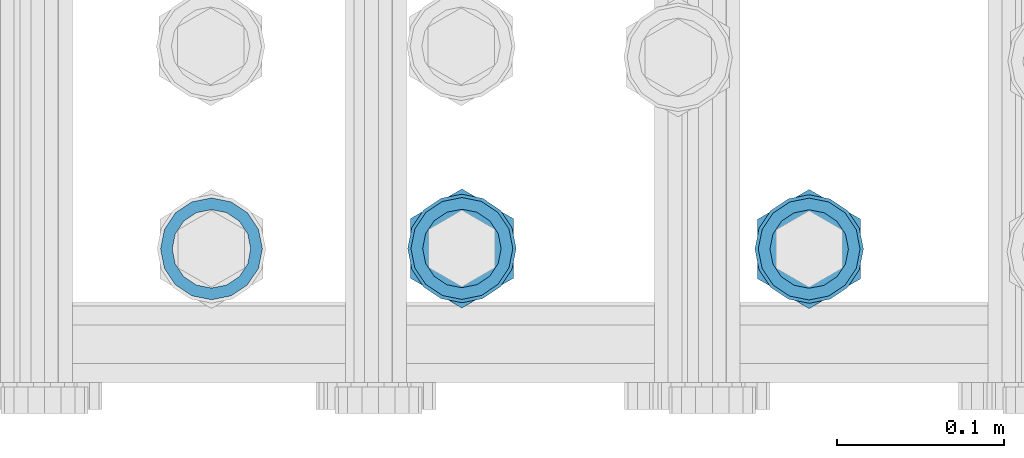
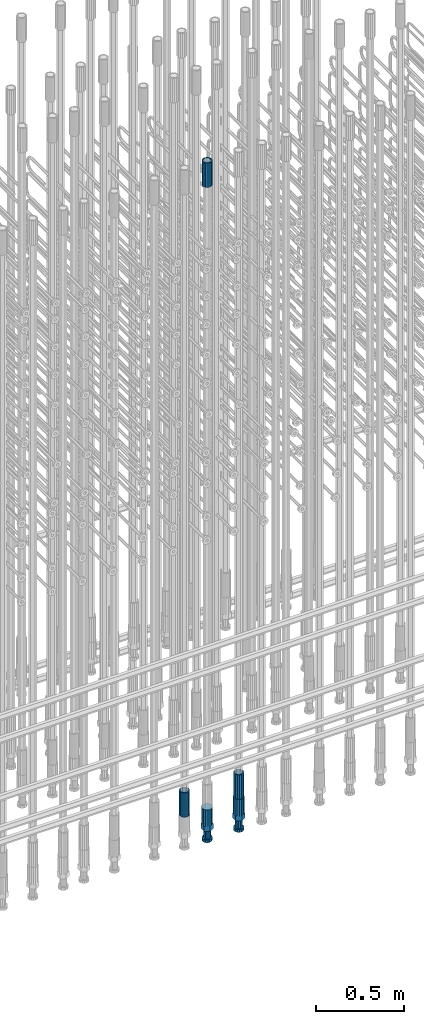
# One storey, part 65 of 177: 5 beams.
"""IFC2X3 building model written with IfcOpenShell, lengths in millimetres."""

from ifc_helpers import new_model, si_unit, frame, origin_with_axes, place, context, subcontext, project, spatial, faceted_brep, material, type_object, element, save


model = new_model("IFC2X3")

# Units and contexts
model_context_1 = context("Model", 3, precision=1e-05, world=origin_with_axes())
model_context_2 = context("Model", 3, precision=1e-05, world=origin_with_axes())
body_context = subcontext(model_context_2, "Body", "Model", "MODEL_VIEW")
ifc_project = project(units=[si_unit("LENGTHUNIT", "METRE", prefix="MILLI"), si_unit("AREAUNIT", "SQUARE_METRE"), si_unit("VOLUMEUNIT", "CUBIC_METRE"), si_unit("MASSUNIT", "GRAM", prefix="KILO"), si_unit("TIMEUNIT", "SECOND"), si_unit("PLANEANGLEUNIT", "RADIAN"), si_unit("SOLIDANGLEUNIT", "STERADIAN"), si_unit("THERMODYNAMICTEMPERATUREUNIT", "DEGREE_CELSIUS"), si_unit("LUMINOUSINTENSITYUNIT", "LUMEN")], contexts=[model_context_1])

# Site, building, storey
site_placement = place(None, origin_with_axes())
site = spatial("IfcSite", under=ifc_project, at=site_placement, CompositionType="ELEMENT")
building_placement = place(site_placement, origin_with_axes())
building = spatial("IfcBuilding", under=site, at=building_placement, Name="Undefined", CompositionType="ELEMENT")
storey_placement = place(building_placement, origin_with_axes())
storey = spatial("IfcBuildingStorey", under=building, at=storey_placement, Name="Undefined", CompositionType="ELEMENT", Elevation=0.0)

# Beams
ifc_material = material(Name="STEEL/S275")
beam_type_1 = type_object("IfcBeamType", PredefinedType="NOTDEFINED")
beam_1_placement = place(storey_placement, frame((2033585.99818842, 6205156.39605988, 22659.9858194829), z_axis=(1.0, 0.0, 0.0), x_axis=(0.0, 0.0, 1.0)))
element("IfcBeam", 1, at=beam_1_placement, inside=storey, type_object=beam_type_1, material=ifc_material, Name="AG40N", context=body_context, shape_type="Brep", body=[
    faceted_brep([(0.0, -23.5000000001164, -9.31322574615479e-10), (0.0, -21.7111690140155, 8.99306066054851), (170.0, -21.7111690140155, 8.99306066054851), (170.0, -23.5, 0.0), (0.0, -16.6170093578839, 16.6170093575493), (170.0, -16.6170093578839, 16.6170093575493), (0.0, -8.99306066057943, 21.7111690137535), (170.0, -8.99306066057943, 21.7111690137535), (0.0, 1.16415321826935e-10, 23.5), (170.0, 0.0, 23.5), (0.0, 8.99306066057943, 21.7111690137535), (170.0, 8.99306066057943, 21.7111690137535), (0.0, 16.6170093578839, 16.6170093575493), (170.0, 16.6170093578839, 16.6170093575493), (0.0, 21.7111690140155, 8.99306066054851), (170.0, 21.7111690140155, 8.99306066054851), (0.0, 23.5000000001164, -9.31322574615479e-10), (170.0, 23.5, 0.0), (0.0, 21.7111690140155, -8.99306066054851), (170.0, 21.7111690140155, -8.99306066054851), (0.0, 16.6170093578839, -16.6170093575493), (170.0, 16.6170093578839, -16.6170093575493), (0.0, 8.99306066057943, -21.7111690137535), (170.0, 8.99306066057943, -21.7111690137535), (0.0, 1.16415321826935e-10, -23.5000000009313), (170.0, 0.0, -23.5), (0.0, -8.99306066057943, -21.7111690137535), (170.0, -8.99306066057943, -21.7111690137535), (0.0, -16.6170093578839, -16.6170093575493), (170.0, -16.6170093578839, -16.6170093575493), (0.0, -21.7111690140155, -8.99306066054851), (170.0, -21.7111690140155, -8.99306066054851), (0.0, -30.5, 0.0), (0.0, -28.1783257415937, -11.6718446873128), (170.0, -28.1783257415937, -11.6718446873128), (170.0, -30.5, 0.0), (0.0, -21.5667568261888, -21.5667568258941), (170.0, -21.5667568261888, -21.5667568258941), (0.0, -11.6718446871346, -28.1783257415518), (170.0, -11.6718446871346, -28.1783257415518), (0.0, 0.0, -30.5), (170.0, 0.0, -30.5), (0.0, 11.6718446871346, -28.1783257415518), (170.0, 11.6718446871346, -28.1783257415518), (0.0, 21.5667568261888, -21.5667568258941), (170.0, 21.5667568261888, -21.5667568258941), (0.0, 28.1783257415937, -11.6718446873128), (170.0, 28.1783257415937, -11.6718446873128), (0.0, 30.5, 0.0), (170.0, 30.5, 0.0), (0.0, 28.1783257415937, 11.6718446873128), (170.0, 28.1783257415937, 11.6718446873128), (0.0, 21.5667568261888, 21.5667568258941), (170.0, 21.5667568261888, 21.5667568258941), (0.0, 11.6718446871346, 28.1783257415518), (170.0, 11.6718446871346, 28.1783257415518), (0.0, 0.0, 30.5), (170.0, 0.0, 30.5), (0.0, -11.6718446871346, 28.1783257415518), (170.0, -11.6718446871346, 28.1783257415518), (0.0, -21.5667568261888, 21.5667568258941), (170.0, -21.5667568261888, 21.5667568258941), (0.0, -28.1783257415937, 11.6718446873128), (170.0, -28.1783257415937, 11.6718446873128)], [[[0, 1, 2, 3]], [[1, 4, 5, 2]], [[4, 6, 7, 5]], [[6, 8, 9, 7]], [[8, 10, 11, 9]], [[10, 12, 13, 11]], [[12, 14, 15, 13]], [[14, 16, 17, 15]], [[16, 18, 19, 17]], [[18, 20, 21, 19]], [[20, 22, 23, 21]], [[22, 24, 25, 23]], [[24, 26, 27, 25]], [[26, 28, 29, 27]], [[28, 30, 31, 29]], [[30, 0, 3, 31]], [[32, 33, 34, 35]], [[33, 36, 37, 34]], [[36, 38, 39, 37]], [[38, 40, 41, 39]], [[40, 42, 43, 41]], [[42, 44, 45, 43]], [[44, 46, 47, 45]], [[46, 48, 49, 47]], [[48, 50, 51, 49]], [[50, 52, 53, 51]], [[52, 54, 55, 53]], [[54, 56, 57, 55]], [[56, 58, 59, 57]], [[58, 60, 61, 59]], [[60, 62, 63, 61]], [[62, 32, 35, 63]], [[37, 39, 41, 43, 45, 47, 49, 51, 53, 55, 57, 59, 61, 63, 35, 34], [5, 7, 9, 11, 13, 15, 17, 19, 21, 23, 25, 27, 29, 31, 3, 2]], [[62, 60, 58, 56, 54, 52, 50, 48, 46, 44, 42, 40, 38, 36, 33, 32], [30, 28, 26, 24, 22, 20, 18, 16, 14, 12, 10, 8, 6, 4, 1, 0]]]),
])
beam_2_placement = place(storey_placement, frame((2033794.01713976, 6205156.06372311, 18490.9668004301), z_axis=(-1.0, 0.0, 0.0), x_axis=(0.0, 0.0, -1.0)))
element("IfcBeam", 2, at=beam_2_placement, inside=storey, type_object=beam_type_1, material=ifc_material, Name="AG40N", context=body_context, shape_type="Brep", body=[
    faceted_brep([(0.0, -23.5000000001164, -9.31322574615479e-10), (0.0, -21.7111690140155, 8.99306066054851), (170.0, -21.7111690140155, 8.99306066054851), (170.0, -23.5, 0.0), (0.0, -16.6170093578839, 16.6170093575493), (170.0, -16.6170093578839, 16.6170093575493), (0.0, -8.99306066057943, 21.7111690137535), (170.0, -8.99306066057943, 21.7111690137535), (0.0, 1.16415321826935e-10, 23.5), (170.0, 0.0, 23.5), (0.0, 8.99306066057943, 21.7111690137535), (170.0, 8.99306066057943, 21.7111690137535), (0.0, 16.6170093578839, 16.6170093575493), (170.0, 16.6170093578839, 16.6170093575493), (0.0, 21.7111690140155, 8.99306066054851), (170.0, 21.7111690140155, 8.99306066054851), (0.0, 23.5000000001164, -9.31322574615479e-10), (170.0, 23.5, 0.0), (0.0, 21.7111690140155, -8.99306066054851), (170.0, 21.7111690140155, -8.99306066054851), (0.0, 16.6170093578839, -16.6170093575493), (170.0, 16.6170093578839, -16.6170093575493), (0.0, 8.99306066057943, -21.7111690137535), (170.0, 8.99306066057943, -21.7111690137535), (0.0, 1.16415321826935e-10, -23.5000000009313), (170.0, 0.0, -23.5), (0.0, -8.99306066057943, -21.7111690137535), (170.0, -8.99306066057943, -21.7111690137535), (0.0, -16.6170093578839, -16.6170093575493), (170.0, -16.6170093578839, -16.6170093575493), (0.0, -21.7111690140155, -8.99306066054851), (170.0, -21.7111690140155, -8.99306066054851), (0.0, -30.5, 0.0), (0.0, -28.1783257415937, -11.6718446873128), (170.0, -28.1783257415937, -11.6718446873128), (170.0, -30.5, 0.0), (0.0, -21.5667568261888, -21.5667568258941), (170.0, -21.5667568261888, -21.5667568258941), (0.0, -11.6718446871346, -28.1783257415518), (170.0, -11.6718446871346, -28.1783257415518), (0.0, 0.0, -30.5), (170.0, 0.0, -30.5), (0.0, 11.6718446871346, -28.1783257415518), (170.0, 11.6718446871346, -28.1783257415518), (0.0, 21.5667568261888, -21.5667568258941), (170.0, 21.5667568261888, -21.5667568258941), (0.0, 28.1783257415937, -11.6718446873128), (170.0, 28.1783257415937, -11.6718446873128), (0.0, 30.5, 0.0), (170.0, 30.5, 0.0), (0.0, 28.1783257415937, 11.6718446873128), (170.0, 28.1783257415937, 11.6718446873128), (0.0, 21.5667568261888, 21.5667568258941), (170.0, 21.5667568261888, 21.5667568258941), (0.0, 11.6718446871346, 28.1783257415518), (170.0, 11.6718446871346, 28.1783257415518), (0.0, 0.0, 30.5), (170.0, 0.0, 30.5), (0.0, -11.6718446871346, 28.1783257415518), (170.0, -11.6718446871346, 28.1783257415518), (0.0, -21.5667568261888, 21.5667568258941), (170.0, -21.5667568261888, 21.5667568258941), (0.0, -28.1783257415937, 11.6718446873128), (170.0, -28.1783257415937, 11.6718446873128)], [[[0, 1, 2, 3]], [[1, 4, 5, 2]], [[4, 6, 7, 5]], [[6, 8, 9, 7]], [[8, 10, 11, 9]], [[10, 12, 13, 11]], [[12, 14, 15, 13]], [[14, 16, 17, 15]], [[16, 18, 19, 17]], [[18, 20, 21, 19]], [[20, 22, 23, 21]], [[22, 24, 25, 23]], [[24, 26, 27, 25]], [[26, 28, 29, 27]], [[28, 30, 31, 29]], [[30, 0, 3, 31]], [[32, 33, 34, 35]], [[33, 36, 37, 34]], [[36, 38, 39, 37]], [[38, 40, 41, 39]], [[40, 42, 43, 41]], [[42, 44, 45, 43]], [[44, 46, 47, 45]], [[46, 48, 49, 47]], [[48, 50, 51, 49]], [[50, 52, 53, 51]], [[52, 54, 55, 53]], [[54, 56, 57, 55]], [[56, 58, 59, 57]], [[58, 60, 61, 59]], [[60, 62, 63, 61]], [[62, 32, 35, 63]], [[37, 39, 41, 43, 45, 47, 49, 51, 53, 55, 57, 59, 61, 63, 35, 34], [5, 7, 9, 11, 13, 15, 17, 19, 21, 23, 25, 27, 29, 31, 3, 2]], [[62, 60, 58, 56, 54, 52, 50, 48, 46, 44, 42, 40, 38, 36, 33, 32], [30, 28, 26, 24, 22, 20, 18, 16, 14, 12, 10, 8, 6, 4, 1, 0]]]),
])
beam_3_placement = place(storey_placement, frame((2033436.01715727, 6205156.16758607, 18490.9668004301), z_axis=(-1.0, 0.0, 0.0), x_axis=(0.0, 0.0, -1.0)))
element("IfcBeam", 3, at=beam_3_placement, inside=storey, type_object=beam_type_1, material=ifc_material, Name="AG40N", context=body_context, shape_type="Brep", body=[
    faceted_brep([(0.0, -23.5000000001164, -9.31322574615479e-10), (0.0, -21.7111690140155, 8.99306066054851), (170.0, -21.7111690140155, 8.99306066054851), (170.0, -23.5, 0.0), (0.0, -16.6170093578839, 16.6170093575493), (170.0, -16.6170093578839, 16.6170093575493), (0.0, -8.99306066057943, 21.7111690137535), (170.0, -8.99306066057943, 21.7111690137535), (0.0, 1.16415321826935e-10, 23.5), (170.0, 0.0, 23.5), (0.0, 8.99306066057943, 21.7111690137535), (170.0, 8.99306066057943, 21.7111690137535), (0.0, 16.6170093578839, 16.6170093575493), (170.0, 16.6170093578839, 16.6170093575493), (0.0, 21.7111690140155, 8.99306066054851), (170.0, 21.7111690140155, 8.99306066054851), (0.0, 23.5000000001164, -9.31322574615479e-10), (170.0, 23.5, 0.0), (0.0, 21.7111690140155, -8.99306066054851), (170.0, 21.7111690140155, -8.99306066054851), (0.0, 16.6170093578839, -16.6170093575493), (170.0, 16.6170093578839, -16.6170093575493), (0.0, 8.99306066057943, -21.7111690137535), (170.0, 8.99306066057943, -21.7111690137535), (0.0, 1.16415321826935e-10, -23.5000000009313), (170.0, 0.0, -23.5), (0.0, -8.99306066057943, -21.7111690137535), (170.0, -8.99306066057943, -21.7111690137535), (0.0, -16.6170093578839, -16.6170093575493), (170.0, -16.6170093578839, -16.6170093575493), (0.0, -21.7111690140155, -8.99306066054851), (170.0, -21.7111690140155, -8.99306066054851), (0.0, -30.5, 0.0), (0.0, -28.1783257415937, -11.6718446873128), (170.0, -28.1783257415937, -11.6718446873128), (170.0, -30.5, 0.0), (0.0, -21.5667568261888, -21.5667568258941), (170.0, -21.5667568261888, -21.5667568258941), (0.0, -11.6718446871346, -28.1783257415518), (170.0, -11.6718446871346, -28.1783257415518), (0.0, 0.0, -30.5), (170.0, 0.0, -30.5), (0.0, 11.6718446871346, -28.1783257415518), (170.0, 11.6718446871346, -28.1783257415518), (0.0, 21.5667568261888, -21.5667568258941), (170.0, 21.5667568261888, -21.5667568258941), (0.0, 28.1783257415937, -11.6718446873128), (170.0, 28.1783257415937, -11.6718446873128), (0.0, 30.5, 0.0), (170.0, 30.5, 0.0), (0.0, 28.1783257415937, 11.6718446873128), (170.0, 28.1783257415937, 11.6718446873128), (0.0, 21.5667568261888, 21.5667568258941), (170.0, 21.5667568261888, 21.5667568258941), (0.0, 11.6718446871346, 28.1783257415518), (170.0, 11.6718446871346, 28.1783257415518), (0.0, 0.0, 30.5), (170.0, 0.0, 30.5), (0.0, -11.6718446871346, 28.1783257415518), (170.0, -11.6718446871346, 28.1783257415518), (0.0, -21.5667568261888, 21.5667568258941), (170.0, -21.5667568261888, 21.5667568258941), (0.0, -28.1783257415937, 11.6718446873128), (170.0, -28.1783257415937, 11.6718446873128)], [[[0, 1, 2, 3]], [[1, 4, 5, 2]], [[4, 6, 7, 5]], [[6, 8, 9, 7]], [[8, 10, 11, 9]], [[10, 12, 13, 11]], [[12, 14, 15, 13]], [[14, 16, 17, 15]], [[16, 18, 19, 17]], [[18, 20, 21, 19]], [[20, 22, 23, 21]], [[22, 24, 25, 23]], [[24, 26, 27, 25]], [[26, 28, 29, 27]], [[28, 30, 31, 29]], [[30, 0, 3, 31]], [[32, 33, 34, 35]], [[33, 36, 37, 34]], [[36, 38, 39, 37]], [[38, 40, 41, 39]], [[40, 42, 43, 41]], [[42, 44, 45, 43]], [[44, 46, 47, 45]], [[46, 48, 49, 47]], [[48, 50, 51, 49]], [[50, 52, 53, 51]], [[52, 54, 55, 53]], [[54, 56, 57, 55]], [[56, 58, 59, 57]], [[58, 60, 61, 59]], [[60, 62, 63, 61]], [[62, 32, 35, 63]], [[37, 39, 41, 43, 45, 47, 49, 51, 53, 55, 57, 59, 61, 63, 35, 34], [5, 7, 9, 11, 13, 15, 17, 19, 21, 23, 25, 27, 29, 31, 3, 2]], [[62, 60, 58, 56, 54, 52, 50, 48, 46, 44, 42, 40, 38, 36, 33, 32], [30, 28, 26, 24, 22, 20, 18, 16, 14, 12, 10, 8, 6, 4, 1, 0]]]),
])
beam_type_2 = type_object("IfcBeamType", Name="ROD65", PredefinedType="NOTDEFINED")
beam_4_placement = place(storey_placement, frame((2033585.99818842, 6205156.39605988, 18320.9668004298), z_axis=(-1.0, 0.0, 0.0), x_axis=(0.0, 0.0, -1.0)))
element("IfcBeam", 4, at=beam_4_placement, inside=storey, type_object=beam_type_2, material=ifc_material, Name="AGB40", ObjectType="ROD65", context=body_context, shape_type="Brep", body=[
    faceted_brep([(117.0, 8.17543110251427, 30.873805644922), (117.0, 17.8250000001863, 30.873805644922), (117.0, 22.0056958701462, 23.6326279877685), (117.0, 12.4372115517035, 30.0260848065373), (117.0, -17.8250000001863, 30.873805644922), (150.200000000186, -17.8250000001863, 30.873805644922), (150.200000000186, 17.8250000001863, 30.873805644922), (117.0, -8.17543110251427, 30.873805644922), (117.0, -12.4372115517035, 30.0260848065373), (117.0, -22.0056958701462, 23.6326279877685), (117.0, -35.6500000003725, 0.0), (150.200000000186, -35.6500000003725, 0.0), (117.0, -30.8443150008097, 8.32369058486074), (117.0, -32.5, 0.0), (117.0, -30.8443150008097, -8.32369058462791), (117.0, -17.8250000001863, -30.873805644922), (150.200000000186, -17.8250000001863, -30.873805644922), (117.0, -22.0056958701462, -23.6326279877685), (117.0, -12.4372115517035, -30.0260848065373), (117.0, -8.17543110251427, -30.873805644922), (117.0, 17.8250000001863, -30.873805644922), (150.200000000186, 17.8250000001863, -30.873805644922), (117.0, 8.17543110251427, -30.873805644922), (117.0, 22.0056958701462, -23.6326279877685), (117.0, 12.4372115517035, -30.0260848065373), (117.0, 35.6500000003725, 0.0), (150.200000000186, 35.6500000003725, 0.0), (117.0, 30.8443150008097, -8.32369058486074), (117.0, 30.8443150008097, 8.32369058462791), (117.0, 32.5, 0.0), (0.0, -22.9809703892097, 22.9809703885621), (0.0, -30.0260848058388, 12.4372115518636), (117.0, -30.0260848067701, 12.4372115519363), (117.0, -22.9809703882784, 22.9809703885112), (-2.3283064365387e-10, 22.9809703892097, -22.9809703885639), (-4.65661287307739e-10, 30.0260848077014, -12.4372115518672), (117.0, 30.0260848067701, -12.4372115519363), (117.0, 22.9809703882784, -22.9809703885112), (-2.3283064365387e-10, -30.0260848067701, -12.4372115518672), (-2.3283064365387e-10, -22.9809703892097, -22.9809703885621), (117.0, -22.9809703882784, -22.9809703885112), (117.0, -30.0260848067701, -12.4372115519363), (-2.3283064365387e-10, -12.4372115507722, 30.0260848066137), (-2.3283064365387e-10, 9.31322574615479e-10, 32.4999999999982), (-2.3283064365387e-10, 12.4372115526348, 30.0260848066137), (0.0, 22.9809703892097, 22.9809703885621), (-2.3283064365387e-10, 30.0260848077014, 12.4372115518636), (-2.3283064365387e-10, 32.5, 0.0), (-2.3283064365387e-10, 12.4372115526348, -30.0260848066173), (-2.3283064365387e-10, 9.31322574615479e-10, -32.5), (-2.3283064365387e-10, -12.4372115517035, -30.0260848066173), (-4.65661287307739e-10, -32.4999999990687, -1.81898940354586e-12), (117.0, 22.9809703882784, 22.9809703885112), (117.0, 30.0260848067701, 12.4372115519363), (117.0, 0.0, -32.5), (117.0, 0.0, 32.5), (150.200000000186, 10.5, -18.1865334794857), (150.200000000186, 0.0, -21.0), (150.200000000186, -10.5, -18.1865334794857), (150.200000000186, -18.18653347902, -10.5), (150.200000000186, -21.0, 0.0), (150.200000000186, -18.18653347902, 10.5), (150.200000000186, -10.5, 18.1865334794857), (150.200000000186, 0.0, 21.0), (150.200000000186, 10.5, 18.1865334794857), (150.200000000186, 18.18653347902, 10.5), (150.200000000186, 21.0, 0.0), (150.200000000186, 18.18653347902, -10.5), (210.980000000447, -10.5, -18.1865334794857), (210.980000000447, 0.0, -21.0), (210.980000000447, -18.18653347902, -10.5), (210.980000000447, -21.0, 0.0), (210.980000000447, -18.18653347902, 10.5), (210.980000000447, -10.5, 18.1865334794857), (210.980000000447, 0.0, 21.0), (210.980000000447, 10.5, 18.1865334794857), (210.980000000447, 18.18653347902, 10.5), (210.980000000447, 21.0, 0.0), (210.980000000447, 18.18653347902, -10.5), (210.980000000447, 10.5, -18.1865334794857), (211.001368442696, -27.7269937992096, -11.491116326768), (211.003082550167, -21.2238094303757, -21.223815418547), (231.002518367059, -21.2131944671273, -21.2132004550658), (231.000804259587, -27.7163788359612, -11.4805013632867), (211.001368440451, -11.4911085031927, -27.7269970395137), (231.000804257343, -11.4804935399443, -27.7163820760325), (210.996487071217, -0.0106065049767494, -30.0106107392348), (230.995922888109, 8.45827162265778e-06, -29.9999957757536), (210.989181586672, 11.46989420522, -27.7269970329944), (230.988617403564, 11.4805091684684, -27.7163820695132), (210.980564180623, 21.2025914648548, -21.2238154064398), (230.979999997515, 21.2132064281031, -21.2132004429586), (210.971946775022, 27.7057703435421, -11.4911163107026), (230.971382591913, 27.7163853067905, -11.4805013472214), (210.96464129175, 29.9893808094785, -0.0106149562634528), (230.964077108642, 29.9999957727268, 7.21774995326996e-09), (210.959759924415, 27.7057638689876, 11.4698863970116), (230.959195741307, 27.7163788322359, 11.4805013604928), (210.958045816944, 21.2025795001537, 21.2025854887906), (230.957481633835, 21.213194463402, 21.2132004522718), (210.95975992666, 11.4698785729706, 27.7057671097573), (230.959195743551, 11.480493536219, 27.7163820732385), (210.964641295894, -0.010623425245285, 29.9893808094785), (230.964077112785, -8.46199691295624e-06, 29.9999957729597), (210.971946780439, -11.4911241354421, 27.705767103238), (230.97138259733, -11.4805091721937, 27.7163820667192), (210.980564186488, -21.2238213950768, 21.2025854766835), (230.980000003379, -21.2132064318284, 21.2132004401647), (210.989181592089, -27.7270002737641, 11.4698863809463), (230.988617408981, -27.7163853105158, 11.4805013444275), (210.996487075361, -30.0106107397005, -0.0106149734929204), (230.995922892253, -29.9999957764521, -1.00117176771164e-08)], [[[0, 1, 2, 3]], [[4, 5, 6, 1, 0, 7]], [[4, 7, 8, 9]], [[10, 11, 5, 4, 9, 12]], [[10, 12, 13, 14]], [[15, 16, 11, 10, 14, 17]], [[15, 17, 18, 19]], [[20, 21, 16, 15, 19, 22]], [[23, 20, 22, 24]], [[25, 26, 21, 20, 23, 27]], [[28, 25, 27, 29]], [[30, 31, 32, 33]], [[34, 35, 36, 37]], [[38, 39, 40, 41]], [[31, 30, 42, 43, 44, 45, 46, 47, 35, 34, 48, 49, 50, 39, 38, 51]], [[46, 45, 52, 53]], [[29, 47, 46, 53, 28]], [[27, 36, 35, 47, 29]], [[23, 37, 36, 27]], [[24, 48, 34, 37, 23]], [[22, 54, 49, 48, 24]], [[19, 54, 22]], [[18, 50, 49, 54, 19]], [[17, 40, 39, 50, 18]], [[14, 41, 40, 17]], [[13, 51, 38, 41, 14]], [[12, 32, 31, 51, 13]], [[9, 33, 32, 12]], [[8, 42, 30, 33, 9]], [[7, 55, 43, 42, 8]], [[0, 55, 7]], [[3, 44, 43, 55, 0]], [[2, 52, 45, 44, 3]], [[28, 53, 52, 2]], [[1, 6, 26, 25, 28, 2]], [[5, 11, 16, 21, 26, 6], [56, 57, 58, 59, 60, 61, 62, 63, 64, 65, 66, 67]], [[68, 58, 57, 69]], [[70, 59, 58, 68]], [[71, 60, 59, 70]], [[72, 61, 60, 71]], [[73, 62, 61, 72]], [[74, 63, 62, 73]], [[75, 64, 63, 74]], [[76, 65, 64, 75]], [[77, 66, 65, 76]], [[78, 67, 66, 77]], [[79, 56, 67, 78]], [[69, 57, 56, 79]], [[80, 81, 82, 83]], [[81, 84, 85, 82]], [[84, 86, 87, 85]], [[86, 88, 89, 87]], [[88, 90, 91, 89]], [[90, 92, 93, 91]], [[92, 94, 95, 93]], [[94, 96, 97, 95]], [[96, 98, 99, 97]], [[98, 100, 101, 99]], [[100, 102, 103, 101]], [[102, 104, 105, 103]], [[104, 106, 107, 105]], [[106, 108, 109, 107]], [[108, 110, 111, 109]], [[82, 85, 87, 89, 91, 93, 95, 97, 99, 101, 103, 105, 107, 109, 111, 83]], [[110, 80, 83, 111]], [[108, 106, 104, 102, 100, 98, 96, 94, 92, 90, 88, 86, 84, 81, 80, 110], [78, 77, 76, 75, 74, 73, 72, 71, 70, 68, 69, 79]]]),
])
beam_5_placement = place(storey_placement, frame((2033794.01713976, 6205156.06372311, 18320.9668004301), z_axis=(-1.0, 0.0, 0.0), x_axis=(0.0, 0.0, -1.0)))
element("IfcBeam", 5, at=beam_5_placement, inside=storey, type_object=beam_type_2, material=ifc_material, Name="AGB40", ObjectType="ROD65", context=body_context, shape_type="Brep", body=[
    faceted_brep([(117.0, 8.17543110251427, 30.873805644922), (117.0, 17.8250000001863, 30.873805644922), (117.0, 22.0056958701462, 23.6326279877685), (117.0, 12.4372115517035, 30.0260848065373), (117.0, -17.8250000001863, 30.873805644922), (150.200000000186, -17.8250000001863, 30.873805644922), (150.200000000186, 17.8250000001863, 30.873805644922), (117.0, -8.17543110251427, 30.873805644922), (117.0, -12.4372115517035, 30.0260848065373), (117.0, -22.0056958701462, 23.6326279877685), (117.0, -35.6500000003725, 0.0), (150.200000000186, -35.6500000003725, 0.0), (117.0, -30.8443150008097, 8.32369058486074), (117.0, -32.5, 0.0), (117.0, -30.8443150008097, -8.32369058462791), (117.0, -17.8250000001863, -30.873805644922), (150.200000000186, -17.8250000001863, -30.873805644922), (117.0, -22.0056958701462, -23.6326279877685), (117.0, -12.4372115517035, -30.0260848065373), (117.0, -8.17543110251427, -30.873805644922), (117.0, 17.8250000001863, -30.873805644922), (150.200000000186, 17.8250000001863, -30.873805644922), (117.0, 8.17543110251427, -30.873805644922), (117.0, 22.0056958701462, -23.6326279877685), (117.0, 12.4372115517035, -30.0260848065373), (117.0, 35.6500000003725, 0.0), (150.200000000186, 35.6500000003725, 0.0), (117.0, 30.8443150008097, -8.32369058486074), (117.0, 30.8443150008097, 8.32369058462791), (117.0, 32.5, 0.0), (0.0, -22.9809703892097, 22.9809703885621), (0.0, -30.0260848058388, 12.4372115518636), (117.0, -30.0260848067701, 12.4372115519363), (117.0, -22.9809703882784, 22.9809703885112), (-2.3283064365387e-10, 22.9809703892097, -22.9809703885639), (-4.65661287307739e-10, 30.0260848077014, -12.4372115518672), (117.0, 30.0260848067701, -12.4372115519363), (117.0, 22.9809703882784, -22.9809703885112), (-2.3283064365387e-10, -30.0260848067701, -12.4372115518672), (-2.3283064365387e-10, -22.9809703892097, -22.9809703885621), (117.0, -22.9809703882784, -22.9809703885112), (117.0, -30.0260848067701, -12.4372115519363), (-2.3283064365387e-10, -12.4372115507722, 30.0260848066137), (-2.3283064365387e-10, 9.31322574615479e-10, 32.4999999999982), (-2.3283064365387e-10, 12.4372115526348, 30.0260848066137), (0.0, 22.9809703892097, 22.9809703885621), (-2.3283064365387e-10, 30.0260848077014, 12.4372115518636), (-2.3283064365387e-10, 32.5, 0.0), (-2.3283064365387e-10, 12.4372115526348, -30.0260848066173), (-2.3283064365387e-10, 9.31322574615479e-10, -32.5), (-2.3283064365387e-10, -12.4372115517035, -30.0260848066173), (-4.65661287307739e-10, -32.4999999990687, -1.81898940354586e-12), (117.0, 22.9809703882784, 22.9809703885112), (117.0, 30.0260848067701, 12.4372115519363), (117.0, 0.0, -32.5), (117.0, 0.0, 32.5), (150.200000000186, 10.5, -18.1865334794857), (150.200000000186, 0.0, -21.0), (150.200000000186, -10.5, -18.1865334794857), (150.200000000186, -18.18653347902, -10.5), (150.200000000186, -21.0, 0.0), (150.200000000186, -18.18653347902, 10.5), (150.200000000186, -10.5, 18.1865334794857), (150.200000000186, 0.0, 21.0), (150.200000000186, 10.5, 18.1865334794857), (150.200000000186, 18.18653347902, 10.5), (150.200000000186, 21.0, 0.0), (150.200000000186, 18.18653347902, -10.5), (210.980000000447, -10.5, -18.1865334794857), (210.980000000447, 0.0, -21.0), (210.980000000447, -18.18653347902, -10.5), (210.980000000447, -21.0, 0.0), (210.980000000447, -18.18653347902, 10.5), (210.980000000447, -10.5, 18.1865334794857), (210.980000000447, 0.0, 21.0), (210.980000000447, 10.5, 18.1865334794857), (210.980000000447, 18.18653347902, 10.5), (210.980000000447, 21.0, 0.0), (210.980000000447, 18.18653347902, -10.5), (210.980000000447, 10.5, -18.1865334794857), (211.001368442696, -27.7269937992096, -11.491116326768), (211.003082550167, -21.2238094303757, -21.223815418547), (231.002518367059, -21.2131944671273, -21.2132004550658), (231.000804259587, -27.7163788359612, -11.4805013632867), (211.001368440451, -11.4911085031927, -27.7269970395137), (231.000804257343, -11.4804935399443, -27.7163820760325), (210.996487071217, -0.0106065049767494, -30.0106107392348), (230.995922888109, 8.45827162265778e-06, -29.9999957757536), (210.989181586672, 11.46989420522, -27.7269970329944), (230.988617403564, 11.4805091684684, -27.7163820695132), (210.980564180623, 21.2025914648548, -21.2238154064398), (230.979999997515, 21.2132064281031, -21.2132004429586), (210.971946775022, 27.7057703435421, -11.4911163107026), (230.971382591913, 27.7163853067905, -11.4805013472214), (210.96464129175, 29.9893808094785, -0.0106149562634528), (230.964077108642, 29.9999957727268, 7.21774995326996e-09), (210.959759924415, 27.7057638689876, 11.4698863970116), (230.959195741307, 27.7163788322359, 11.4805013604928), (210.958045816944, 21.2025795001537, 21.2025854887906), (230.957481633835, 21.213194463402, 21.2132004522718), (210.95975992666, 11.4698785729706, 27.7057671097573), (230.959195743551, 11.480493536219, 27.7163820732385), (210.964641295894, -0.010623425245285, 29.9893808094785), (230.964077112785, -8.46199691295624e-06, 29.9999957729597), (210.971946780439, -11.4911241354421, 27.705767103238), (230.97138259733, -11.4805091721937, 27.7163820667192), (210.980564186488, -21.2238213950768, 21.2025854766835), (230.980000003379, -21.2132064318284, 21.2132004401647), (210.989181592089, -27.7270002737641, 11.4698863809463), (230.988617408981, -27.7163853105158, 11.4805013444275), (210.996487075361, -30.0106107397005, -0.0106149734929204), (230.995922892253, -29.9999957764521, -1.00117176771164e-08)], [[[0, 1, 2, 3]], [[4, 5, 6, 1, 0, 7]], [[4, 7, 8, 9]], [[10, 11, 5, 4, 9, 12]], [[10, 12, 13, 14]], [[15, 16, 11, 10, 14, 17]], [[15, 17, 18, 19]], [[20, 21, 16, 15, 19, 22]], [[23, 20, 22, 24]], [[25, 26, 21, 20, 23, 27]], [[28, 25, 27, 29]], [[30, 31, 32, 33]], [[34, 35, 36, 37]], [[38, 39, 40, 41]], [[31, 30, 42, 43, 44, 45, 46, 47, 35, 34, 48, 49, 50, 39, 38, 51]], [[46, 45, 52, 53]], [[29, 47, 46, 53, 28]], [[27, 36, 35, 47, 29]], [[23, 37, 36, 27]], [[24, 48, 34, 37, 23]], [[22, 54, 49, 48, 24]], [[19, 54, 22]], [[18, 50, 49, 54, 19]], [[17, 40, 39, 50, 18]], [[14, 41, 40, 17]], [[13, 51, 38, 41, 14]], [[12, 32, 31, 51, 13]], [[9, 33, 32, 12]], [[8, 42, 30, 33, 9]], [[7, 55, 43, 42, 8]], [[0, 55, 7]], [[3, 44, 43, 55, 0]], [[2, 52, 45, 44, 3]], [[28, 53, 52, 2]], [[1, 6, 26, 25, 28, 2]], [[5, 11, 16, 21, 26, 6], [56, 57, 58, 59, 60, 61, 62, 63, 64, 65, 66, 67]], [[68, 58, 57, 69]], [[70, 59, 58, 68]], [[71, 60, 59, 70]], [[72, 61, 60, 71]], [[73, 62, 61, 72]], [[74, 63, 62, 73]], [[75, 64, 63, 74]], [[76, 65, 64, 75]], [[77, 66, 65, 76]], [[78, 67, 66, 77]], [[79, 56, 67, 78]], [[69, 57, 56, 79]], [[80, 81, 82, 83]], [[81, 84, 85, 82]], [[84, 86, 87, 85]], [[86, 88, 89, 87]], [[88, 90, 91, 89]], [[90, 92, 93, 91]], [[92, 94, 95, 93]], [[94, 96, 97, 95]], [[96, 98, 99, 97]], [[98, 100, 101, 99]], [[100, 102, 103, 101]], [[102, 104, 105, 103]], [[104, 106, 107, 105]], [[106, 108, 109, 107]], [[108, 110, 111, 109]], [[82, 85, 87, 89, 91, 93, 95, 97, 99, 101, 103, 105, 107, 109, 111, 83]], [[110, 80, 83, 111]], [[108, 106, 104, 102, 100, 98, 96, 94, 92, 90, 88, 86, 84, 81, 80, 110], [78, 77, 76, 75, 74, 73, 72, 71, 70, 68, 69, 79]]]),
])

save(model, "model.ifc")
